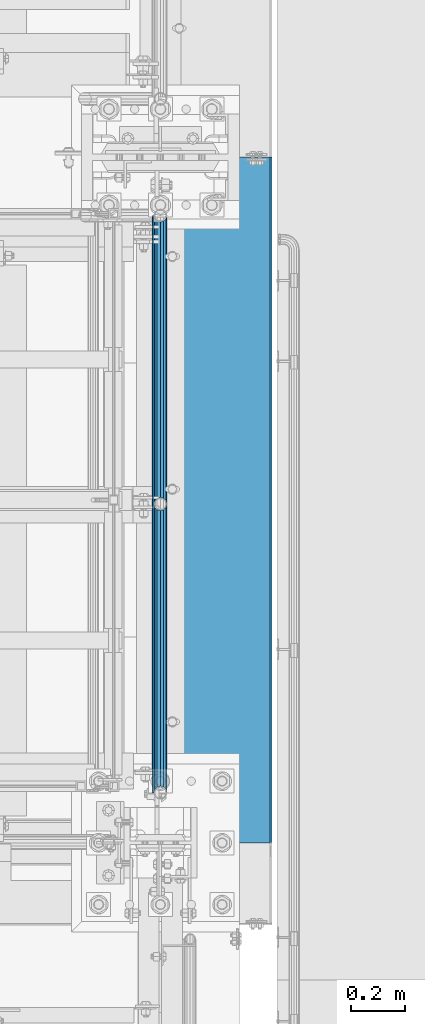
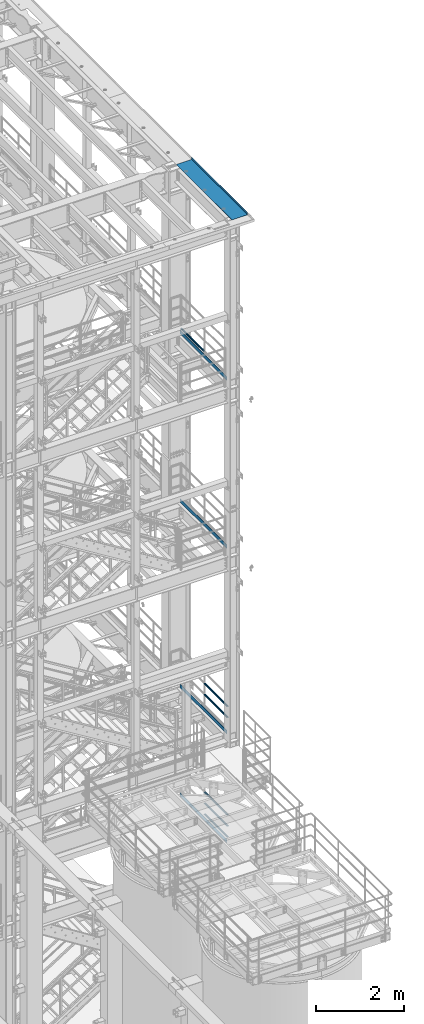
# One storey, part 1000 of 1876: 11 beams, 5 elements without a shape of their own.
"""IFC2X3 building model written with IfcOpenShell, lengths in millimetres."""

import ifcopenshell
import ifcopenshell.guid

model = None  # the IFC model being written
_history = None  # IfcOwnerHistory: only IFC2X3 demands one
_inside = {}  # id of a spatial element -> (the spatial element, [elements in it])
_under = {}  # id of a project, library or spatial element -> (it, [spatial elements below it])
_declared = {}  # id of a project -> (the project, [libraries it declares])
_typed = {}  # id of a type object -> (the type object, [elements of that type])
_made_of = {}  # id of a material, layer set ... -> (it, [elements and type objects made of it])


def new_model(schema):
    """Start an empty IFC model of exactly this schema.

    Asked for "IFC4X3", IfcOpenShell would pick the latest addendum, in which some entities
    have other attributes; the version numbers below select the first issue.
    IFC2X3 requires an IfcOwnerHistory on every rooted entity: one is made here for all.
    """
    global model, _history
    if schema == "IFC4X3":
        model = ifcopenshell.file(schema_version=(4, 3, 0, 0))
    else:
        model = ifcopenshell.file(schema=schema)
    _inside.clear()
    _under.clear()
    _declared.clear()
    _typed.clear()
    _made_of.clear()
    _history = None
    if model.schema == "IFC2X3":
        org = make("IfcOrganization", Name="unknown")
        user = make(
            "IfcPersonAndOrganization",
            ThePerson=make("IfcPerson", FamilyName="unknown"),
            TheOrganization=org,
        )
        app = make(
            "IfcApplication",
            ApplicationDeveloper=org,
            Version="unknown",
            ApplicationFullName="unknown",
            ApplicationIdentifier="unknown",
        )
        _history = make(
            "IfcOwnerHistory",
            OwningUser=user,
            OwningApplication=app,
            ChangeAction="ADDED",
            CreationDate=0,
        )
    return model


def make(cls, **values):
    """One entity of the class cls with the attributes given. An attribute that is None is left unset."""
    return model.create_entity(
        cls, **{name: value for name, value in values.items() if value is not None}
    )


def rooted(cls, **values):
    """An entity with a GlobalId (a new one), such as an element, a storey or a relation."""
    return make(cls, GlobalId=ifcopenshell.guid.new(), OwnerHistory=_history, **values)


def si_unit(unit_type, name, prefix=None):
    """IfcSIUnit, for example si_unit("LENGTHUNIT", "METRE", prefix="MILLI")."""
    return make("IfcSIUnit", UnitType=unit_type, Prefix=prefix, Name=name)


def assignment(units):
    """IfcUnitAssignment: the units of a project."""
    return None if units is None else make("IfcUnitAssignment", Units=units)


def point(xyz):
    """IfcCartesianPoint."""
    return None if xyz is None else make("IfcCartesianPoint", Coordinates=xyz)


def direction(xyz):
    """IfcDirection."""
    return None if xyz is None else make("IfcDirection", DirectionRatios=xyz)


def frame(location, z_axis=None, x_axis=None):
    """IfcAxis2Placement3D, a coordinate frame: its origin and axes. An axis left out is left unset."""
    return make(
        "IfcAxis2Placement3D",
        Location=point(location),
        Axis=direction(z_axis),
        RefDirection=direction(x_axis),
    )


def origin_with_axes():
    """The frame at (0, 0, 0) with the z axis (0, 0, 1) and the x axis (1, 0, 0) written out."""
    return frame((0.0, 0.0, 0.0), z_axis=(0.0, 0.0, 1.0), x_axis=(1.0, 0.0, 0.0))


def place(relative_to, where):
    """IfcLocalPlacement: puts the frame where relative to a parent placement (None: the world)."""
    return make(
        "IfcLocalPlacement", PlacementRelTo=relative_to, RelativePlacement=where
    )


def context(
    kind, dimensions, precision=None, world=None, true_north=None, identifier=None
):
    """IfcGeometricRepresentationContext, for example the 3D "Model" context."""
    return make(
        "IfcGeometricRepresentationContext",
        ContextIdentifier=identifier,
        ContextType=kind,
        CoordinateSpaceDimension=dimensions,
        Precision=precision,
        WorldCoordinateSystem=world,
        TrueNorth=true_north,
    )


def subcontext(parent, identifier, kind, view, scale=None):
    """IfcGeometricRepresentationSubContext, for example "Body" below "Model"."""
    return make(
        "IfcGeometricRepresentationSubContext",
        ContextIdentifier=identifier,
        ContextType=kind,
        ParentContext=parent,
        TargetScale=scale,
        TargetView=view,
    )


def project(units=None, contexts=None):
    """IfcProject with its units and contexts."""
    return rooted(
        "IfcProject",
        Name="project",
        RepresentationContexts=contexts,
        UnitsInContext=assignment(units),
    )


def spatial(cls, under=None, at=None, **own):
    """A site, building, storey or space (cls), placed at a placement, below another one or the project."""
    s = rooted(cls, ObjectPlacement=at, **own)
    if under is not None:
        _under.setdefault(under.id(), (under, []))[1].append(s)
    return s


def faces_of(points, faces, orient=None, outer=None):
    """IfcFace entities. A face is a list of loops; a loop is a list of indices into points, from 0.

    orient and outer hold one flag for each loop. By default every Orientation is true, the
    first loop of a face is its IfcFaceOuterBound and the others are IfcFaceBound.
    """
    made = []
    for i, loops in enumerate(faces):
        bounds = []
        for j, loop in enumerate(loops):
            is_outer = j == 0 if outer is None else outer[i][j]
            bounds.append(
                make(
                    "IfcFaceOuterBound" if is_outer else "IfcFaceBound",
                    Bound=make("IfcPolyLoop", Polygon=[points[k] for k in loop]),
                    Orientation=True if orient is None else orient[i][j],
                )
            )
        made.append(make("IfcFace", Bounds=bounds))
    return made


def faceted_brep(points, faces, orient=None, outer=None, voids=None):
    """IfcFacetedBrep: a solid bounded by flat faces; with voids (closed shells), ...WithVoids."""
    shared = [point(p) for p in points]
    hull = make("IfcClosedShell", CfsFaces=faces_of(shared, faces, orient, outer))
    if voids is None:
        return make("IfcFacetedBrep", Outer=hull)
    return make(
        "IfcFacetedBrepWithVoids",
        Outer=hull,
        Voids=[
            make(cls, CfsFaces=faces_of(shared, fs, o, b)) for cls, fs, o, b in voids
        ],
    )


def shape(context_of_items, identifier, shape_type, items):
    """IfcShapeRepresentation: the items that make up one representation, for example the "Body"."""
    return make(
        "IfcShapeRepresentation",
        ContextOfItems=context_of_items,
        RepresentationIdentifier=identifier,
        RepresentationType=shape_type,
        Items=items,
    )


def material(Name=None, Category=None):
    """IfcMaterial."""
    return make("IfcMaterial", Name=Name, Category=Category)


def made_of(thing, what):
    """Note that an element or type object is made of a material, layer set ...; save() writes the relation."""
    if what is not None:
        _made_of.setdefault(what.id(), (what, []))[1].append(thing)
    return thing


def type_object(cls, material=None, **own):
    """A type object (cls), such as IfcWallType, which elements share."""
    return made_of(rooted(cls, **own), material)


def element(
    cls,
    number,
    at=None,
    inside=None,
    cuts=None,
    type_object=None,
    material=None,
    context=None,
    identifier="Body",
    shape_type=None,
    held_by="IfcProductDefinitionShape",
    body=None,
    shapes=None,
    **own,
):
    """One element of the class cls, such as IfcWall. Its Tag is "e" and its number.

    at: its placement. inside: the storey or other place that contains it. cuts: it is an
    opening in that element (IfcRelVoidsElement). A single representation is given by context,
    identifier, shape_type and body (its items); several are given by shapes. held_by: the class
    of the entity that holds the representations. save() writes the other relations.
    """
    e = rooted(cls, Tag="e%d" % number, ObjectPlacement=at, **own)
    if body is not None:
        shapes = [shape(context, identifier, shape_type, body)]
    if shapes is not None:
        e.Representation = make(held_by, Representations=shapes)
    if inside is not None:
        _inside.setdefault(inside.id(), (inside, []))[1].append(e)
    if cuts is not None:
        rooted(
            "IfcRelVoidsElement", RelatingBuildingElement=cuts, RelatedOpeningElement=e
        )
    if type_object is not None:
        _typed.setdefault(type_object.id(), (type_object, []))[1].append(e)
    return made_of(e, material)


def aggregate(whole, parts):
    """IfcRelAggregates: a whole, such as a stair, and the parts it consists of."""
    return rooted("IfcRelAggregates", RelatingObject=whole, RelatedObjects=parts)


def save(model, path):
    """Write the relations noted so far, then the file.

    IfcRelAggregates (storeys below a building ...), IfcRelContainedInSpatialStructure (elements
    in a storey), IfcRelDefinesByType, IfcRelAssociatesMaterial and IfcRelDeclares: one each for
    every whole, place, type object, material and project.
    """
    for whole, parts in _under.values():
        aggregate(whole, parts)
    for where, things in _inside.values():
        rooted(
            "IfcRelContainedInSpatialStructure",
            RelatedElements=things,
            RelatingStructure=where,
        )
    for kind, things in _typed.values():
        rooted("IfcRelDefinesByType", RelatedObjects=things, RelatingType=kind)
    for what, things in _made_of.values():
        rooted("IfcRelAssociatesMaterial", RelatedObjects=things, RelatingMaterial=what)
    for by, libraries in _declared.values():
        rooted("IfcRelDeclares", RelatingContext=by, RelatedDefinitions=libraries)
    model.write(path)


model = new_model("IFC2X3")

# Units and contexts
model_context = context("Model", 3, precision=1e-05, world=origin_with_axes())
body_context = subcontext(model_context, "Body", "Model", "MODEL_VIEW")
ifc_project = project(units=[si_unit("LENGTHUNIT", "METRE", prefix="MILLI"), si_unit("AREAUNIT", "SQUARE_METRE"), si_unit("VOLUMEUNIT", "CUBIC_METRE"), si_unit("MASSUNIT", "GRAM", prefix="KILO"), si_unit("TIMEUNIT", "SECOND"), si_unit("PLANEANGLEUNIT", "RADIAN"), si_unit("SOLIDANGLEUNIT", "STERADIAN"), si_unit("THERMODYNAMICTEMPERATUREUNIT", "DEGREE_CELSIUS"), si_unit("LUMINOUSINTENSITYUNIT", "LUMEN")], contexts=[model_context])

# Site, building, storey
site_placement = place(None, origin_with_axes())
site = spatial("IfcSite", under=ifc_project, at=site_placement, CompositionType="ELEMENT")
building_placement = place(site_placement, origin_with_axes())
building = spatial("IfcBuilding", under=site, at=building_placement, Name="Undefined", CompositionType="ELEMENT")
storey_placement = place(building_placement, origin_with_axes())
storey = spatial("IfcBuildingStorey", under=building, at=storey_placement, Name="Undefined", CompositionType="ELEMENT", Elevation=0.0)

# Assembly, beam
assembly_1_placement = place(storey_placement, origin_with_axes())
assembly_1 = element("IfcElementAssembly", 1, at=assembly_1_placement, inside=storey, Name="RAIL", AssemblyPlace="NOTDEFINED", PredefinedType="RIGID_FRAME")
ifc_material_1 = material()
beam_type_1 = type_object("IfcBeamType", Name="PIPE1-1/2SCH40", PredefinedType="NOTDEFINED")
beam_1_placement = place(assembly_1_placement, frame((7619.99999999997, -4788.2175, 18145.125), z_axis=(0.0, 0.0, 1.0), x_axis=(0.0, -1.0, 0.0)))
beam_1 = element("IfcBeam", 2, at=beam_1_placement, type_object=beam_type_1, material=ifc_material_1, Name="RAIL", ObjectType="PIPE1-1/2SCH40", context=body_context, shape_type="Brep", body=[
    faceted_brep([(1047.96655700668, -12.0649999999996, 20.8971929933177), (1047.96655700668, -12.0649999999787, 15.8661214312015), (1047.47312856882, -10.2235000000001, 17.7076214311819), (1044.73375, 9.09494701772928e-13, 20.4470000000001), (1044.73375, 9.09494701772928e-13, 24.130000000001), (1047.47312856881, 10.2235000000001, 17.7076214311819), (1047.96655700668, 12.0650000000205, 15.8661214311578), (1047.96655700668, 12.0649999999996, 20.8971929933177), (1068.86375, 24.1300000000001, 0.0), (1056.79875, 20.8971929933186, 12.0649999999987), (1056.79875, 20.8971929933186, -12.0649999999987), (1053.60917843784, 17.7076214311801, 10.2235000000001), (1056.34855700666, 20.4470000000001, 0.0), (1053.60917843784, 17.7076214311801, -10.2235000000001), (1047.96655700668, 12.0650000000205, -15.8661214311578), (1047.96655700668, 12.0649999999996, -20.8971929933177), (1047.47312856881, 10.2235000000001, -17.7076214311819), (1044.73375, 0.0, -20.4470000000001), (1044.73375, 0.0, -24.130000000001), (1047.96655700668, -12.0649999999787, -15.8661214312015), (1047.96655700668, -12.0649999999996, -20.8971929933177), (1047.47312856882, -10.2235000000001, -17.7076214311819), (1068.86375, -24.1299999999792, 0.0), (1056.79875, -20.8971929933186, -12.0649999999987), (1056.79875, -20.8971929933186, 12.0649999999987), (1053.60917843788, -17.7076214311801, -10.2235000000001), (1056.3485570067, -20.4470000000001, 0.0), (1053.60917843788, -17.7076214311801, 10.2235000000001), (12.0650000000064, -20.8971929933177, -12.0649999999987), (20.8971929933249, -12.0650000000005, -20.8971929933177), (0.0, 24.1299999999992, 0.0), (12.0650000000064, 20.8971929933177, -12.0649999999987), (12.0650000000064, 20.8971929933177, 12.0649999999987), (20.8971929933249, 12.0650000000005, 20.8971929933177), (24.1300000000064, 0.0, 24.130000000001), (20.8971929933249, 12.0650000000005, -20.8971929933177), (24.1300000000063, 0.0, -24.130000000001), (24.1300000000063, 0.0, -20.4470000000001), (20.8971929933249, -12.0650000000005, -15.8661214311796), (21.3906214311868, -10.2235000000001, -17.7076214311819), (21.3906214311868, 10.2235000000001, -17.7076214311819), (20.8971929933249, 12.0650000000005, -15.8661214311796), (15.2545715621445, 17.7076214311801, -10.2235000000001), (12.5151929933249, 20.4470000000001, 0.0), (15.2545715621445, 17.7076214311801, 10.2235000000001), (20.8971929933249, 12.0650000000005, 15.8661214311796), (21.3906214311868, 10.2235000000001, 17.7076214311819), (24.1300000000064, 0.0, 20.4470000000001), (21.3906214311868, -10.2235000000001, 17.7076214311819), (20.8971929933249, -12.0650000000005, 15.8661214311796), (20.8971929933249, -12.0650000000005, 20.8971929933177), (12.0650000000064, -20.8971929933177, 12.0649999999987), (0.0, -24.1299999999992, 0.0), (15.2545715621445, -17.7076214311801, 10.2235000000001), (12.5151929933249, -20.4470000000001, 0.0), (15.2545715621445, -17.7076214311801, -10.2235000000001)], [[[0, 1, 2, 3, 4]], [[4, 3, 5, 6, 7]], [[8, 9, 10]], [[7, 6, 11, 12, 13, 14, 15, 10, 9]], [[16, 17, 18, 15, 14]], [[19, 20, 18, 17, 21]], [[22, 23, 24]], [[24, 23, 20, 19, 25, 26, 27, 1, 0]], [[28, 29, 20, 23]], [[30, 31, 32]], [[33, 34, 4, 7]], [[32, 33, 7, 9]], [[30, 32, 9, 8]], [[31, 30, 8, 10]], [[35, 31, 10, 15]], [[36, 35, 15, 18]], [[29, 36, 18, 20]], [[37, 36, 29, 38, 39]], [[40, 41, 35, 36, 37]], [[32, 31, 35, 41, 42, 43, 44, 45, 33]], [[33, 45, 46, 47, 34]], [[34, 47, 48, 49, 50]], [[34, 50, 0, 4]], [[50, 51, 24, 0]], [[51, 52, 22, 24]], [[52, 28, 23, 22]], [[51, 28, 52]], [[50, 49, 53, 54, 55, 38, 29, 28, 51]], [[55, 54, 26, 25]], [[21, 39, 38, 55, 25, 19]], [[37, 39, 21, 17]], [[40, 37, 17, 16]], [[42, 41, 40, 16, 14, 13]], [[43, 42, 13, 12]], [[44, 43, 12, 11]], [[5, 46, 45, 44, 11, 6]], [[47, 46, 5, 3]], [[48, 47, 3, 2]], [[53, 49, 48, 2, 1, 27]], [[54, 53, 27, 26]]]),
])

# Assembly, beams
assembly_2_placement = place(storey_placement, origin_with_axes())
assembly_2 = element("IfcElementAssembly", 3, at=assembly_2_placement, inside=storey, Name="RAIL", AssemblyPlace="NOTDEFINED", PredefinedType="RIGID_FRAME")
beam_2_placement = place(assembly_2_placement, frame((7620.00000000003, -6925.94499999999, 8620.125), z_axis=(0.0, 0.0, -1.0), x_axis=(0.0, 1.0, 0.0)))
beam_2 = element("IfcBeam", 4, at=beam_2_placement, type_object=beam_type_1, material=ifc_material_1, Name="RAIL", ObjectType="PIPE1-1/2SCH40", context=body_context, shape_type="Brep", body=[
    faceted_brep([(0.0, 24.1299999999992, 0.0), (12.0650000000064, 20.8971929933177, -12.0649999999987), (12.0650000000064, 20.8971929933177, 12.0649999999987), (12.0650000000064, -20.8971929933177, 12.0649999999987), (12.0650000000064, -20.8971929933177, -12.0649999999987), (0.0, -24.1299999999992, 0.0), (20.8971929933249, -12.0650000000005, 20.8971929933177), (20.8971929933249, -12.0650000000005, 15.8661214311796), (15.2545715621445, -17.7076214311801, 10.2235000000001), (12.5151929933249, -20.4470000000001, 0.0), (15.2545715621445, -17.7076214311801, -10.2235000000001), (20.8971929933249, -12.0650000000005, -15.8661214311796), (20.8971929933249, -12.0650000000005, -20.8971929933177), (24.1300000000063, 0.0, -20.4470000000001), (24.1300000000063, 0.0, -24.130000000001), (21.3906214311868, -10.2235000000001, -17.7076214311819), (21.3906214311868, 10.2235000000001, -17.7076214311819), (20.8971929933249, 12.0650000000005, -15.8661214311796), (20.8971929933249, 12.0650000000005, -20.8971929933177), (15.2545715621445, 17.7076214311801, -10.2235000000001), (12.5151929933249, 20.4470000000001, 0.0), (15.2545715621445, 17.7076214311801, 10.2235000000001), (20.8971929933249, 12.0650000000005, 15.8661214311796), (20.8971929933249, 12.0650000000005, 20.8971929933177), (21.3906214311868, 10.2235000000001, 17.7076214311819), (24.1300000000064, 0.0, 20.4470000000001), (24.1300000000064, 0.0, 24.130000000001), (21.3906214311868, -10.2235000000001, 17.7076214311819), (1068.86375, 24.1300000000001, 0.0), (1056.79875, 20.8971929933186, -12.0649999999987), (1047.96655700668, 12.0649999999996, -20.8971929933177), (1068.86375, -24.1299999999792, 0.0), (1056.79875, -20.8971929933186, -12.0649999999987), (1056.79875, -20.8971929933186, 12.0649999999987), (1047.96655700668, -12.0649999999996, 20.8971929933177), (1047.96655700668, -12.0649999999996, -20.8971929933177), (1044.73375, 0.0, -24.130000000001), (1047.47312856881, 10.2235000000001, -17.7076214311819), (1044.73375, 0.0, -20.4470000000001), (1047.96655700668, 12.0650000000205, -15.8661214311578), (1047.96655700668, -12.0649999999787, -15.8661214312015), (1047.47312856882, -10.2235000000001, -17.7076214311819), (1053.60917843788, -17.7076214311801, -10.2235000000001), (1056.3485570067, -20.4470000000001, 0.0), (1053.60917843788, -17.7076214311801, 10.2235000000001), (1047.96655700668, -12.0649999999787, 15.8661214312015), (1047.47312856882, -10.2235000000001, 17.7076214311819), (1044.73375, 9.09494701772928e-13, 20.4470000000001), (1044.73375, 9.09494701772928e-13, 24.130000000001), (1047.96655700668, 12.0649999999996, 20.8971929933177), (1056.79875, 20.8971929933186, 12.0649999999987), (1047.96655700668, 12.0650000000205, 15.8661214311578), (1053.60917843784, 17.7076214311801, 10.2235000000001), (1056.34855700666, 20.4470000000001, 0.0), (1053.60917843784, 17.7076214311801, -10.2235000000001), (1047.47312856881, 10.2235000000001, 17.7076214311819)], [[[0, 1, 2]], [[3, 4, 5]], [[6, 7, 8, 9, 10, 11, 12, 4, 3]], [[13, 14, 12, 11, 15]], [[16, 17, 18, 14, 13]], [[2, 1, 18, 17, 19, 20, 21, 22, 23]], [[23, 22, 24, 25, 26]], [[26, 25, 27, 7, 6]], [[1, 0, 28, 29]], [[18, 1, 29, 30]], [[31, 32, 33]], [[6, 3, 33, 34]], [[3, 5, 31, 33]], [[5, 4, 32, 31]], [[4, 12, 35, 32]], [[12, 14, 36, 35]], [[14, 18, 30, 36]], [[37, 38, 36, 30, 39]], [[40, 35, 36, 38, 41]], [[33, 32, 35, 40, 42, 43, 44, 45, 34]], [[34, 45, 46, 47, 48]], [[26, 6, 34, 48]], [[2, 23, 49, 50]], [[23, 26, 48, 49]], [[0, 2, 50, 28]], [[28, 50, 29]], [[49, 51, 52, 53, 54, 39, 30, 29, 50]], [[48, 47, 55, 51, 49]], [[25, 24, 55, 47]], [[55, 24, 22, 21, 52, 51]], [[21, 20, 53, 52]], [[20, 19, 54, 53]], [[19, 17, 16, 37, 39, 54]], [[16, 13, 38, 37]], [[13, 15, 41, 38]], [[41, 15, 11, 10, 42, 40]], [[10, 9, 43, 42]], [[9, 8, 44, 43]], [[8, 7, 27, 46, 45, 44]], [[27, 25, 47, 46]]]),
])
beam_3_placement = place(assembly_2_placement, frame((7620.00000000003, -6925.94499999999, 8924.925), z_axis=(0.0, 0.0, -1.0), x_axis=(0.0, 1.0, 0.0)))
beam_3 = element("IfcBeam", 5, at=beam_3_placement, type_object=beam_type_1, material=ifc_material_1, Name="RAIL", ObjectType="PIPE1-1/2SCH40", context=body_context, shape_type="Brep", body=[
    faceted_brep([(0.0, 24.1299999999992, 0.0), (12.0650000000064, 20.8971929933177, -12.0649999999987), (12.0650000000064, 20.8971929933177, 12.0649999999987), (12.0650000000064, -20.8971929933177, 12.0649999999987), (12.0650000000064, -20.8971929933177, -12.0649999999987), (0.0, -24.1299999999992, 0.0), (20.8971929933249, -12.0650000000005, 20.8971929933177), (20.8971929933249, -12.0650000000005, 15.8661214311796), (15.2545715621445, -17.7076214311801, 10.2235000000001), (12.5151929933249, -20.4470000000001, 0.0), (15.2545715621445, -17.7076214311801, -10.2235000000001), (20.8971929933249, -12.0650000000005, -15.8661214311796), (20.8971929933249, -12.0650000000005, -20.8971929933177), (24.1300000000063, 0.0, -20.4470000000001), (24.1300000000063, 0.0, -24.130000000001), (21.3906214311868, -10.2235000000001, -17.7076214311819), (21.3906214311868, 10.2235000000001, -17.7076214311819), (20.8971929933249, 12.0650000000005, -15.8661214311796), (20.8971929933249, 12.0650000000005, -20.8971929933177), (15.2545715621445, 17.7076214311801, -10.2235000000001), (12.5151929933249, 20.4470000000001, 0.0), (15.2545715621445, 17.7076214311801, 10.2235000000001), (20.8971929933249, 12.0650000000005, 15.8661214311796), (20.8971929933249, 12.0650000000005, 20.8971929933177), (21.3906214311868, 10.2235000000001, 17.7076214311819), (24.1300000000064, 0.0, 20.4470000000001), (24.1300000000064, 0.0, 24.130000000001), (21.3906214311868, -10.2235000000001, 17.7076214311819), (1068.86375, 24.1300000000001, 0.0), (1056.79875, 20.8971929933186, -12.0649999999987), (1047.96655700668, 12.0649999999996, -20.8971929933177), (1068.86375, -24.1299999999792, 0.0), (1056.79875, -20.8971929933186, -12.0649999999987), (1056.79875, -20.8971929933186, 12.0649999999987), (1047.96655700668, -12.0649999999996, 20.8971929933177), (1047.96655700668, -12.0649999999996, -20.8971929933177), (1044.73375, 0.0, -24.130000000001), (1047.47312856881, 10.2235000000001, -17.7076214311819), (1044.73375, 0.0, -20.4470000000001), (1047.96655700668, 12.0650000000205, -15.8661214311578), (1047.96655700668, -12.0649999999787, -15.8661214312015), (1047.47312856882, -10.2235000000001, -17.7076214311819), (1053.60917843788, -17.7076214311801, -10.2235000000001), (1056.3485570067, -20.4470000000001, 0.0), (1053.60917843788, -17.7076214311801, 10.2235000000001), (1047.96655700668, -12.0649999999787, 15.8661214312015), (1047.47312856882, -10.2235000000001, 17.7076214311819), (1044.73375, 9.09494701772928e-13, 20.4470000000001), (1044.73375, 9.09494701772928e-13, 24.130000000001), (1047.96655700668, 12.0649999999996, 20.8971929933177), (1056.79875, 20.8971929933186, 12.0649999999987), (1047.96655700668, 12.0650000000205, 15.8661214311578), (1053.60917843784, 17.7076214311801, 10.2235000000001), (1056.34855700666, 20.4470000000001, 0.0), (1053.60917843784, 17.7076214311801, -10.2235000000001), (1047.47312856881, 10.2235000000001, 17.7076214311819)], [[[0, 1, 2]], [[3, 4, 5]], [[6, 7, 8, 9, 10, 11, 12, 4, 3]], [[13, 14, 12, 11, 15]], [[16, 17, 18, 14, 13]], [[2, 1, 18, 17, 19, 20, 21, 22, 23]], [[23, 22, 24, 25, 26]], [[26, 25, 27, 7, 6]], [[1, 0, 28, 29]], [[18, 1, 29, 30]], [[31, 32, 33]], [[6, 3, 33, 34]], [[3, 5, 31, 33]], [[5, 4, 32, 31]], [[4, 12, 35, 32]], [[12, 14, 36, 35]], [[14, 18, 30, 36]], [[37, 38, 36, 30, 39]], [[40, 35, 36, 38, 41]], [[33, 32, 35, 40, 42, 43, 44, 45, 34]], [[34, 45, 46, 47, 48]], [[26, 6, 34, 48]], [[2, 23, 49, 50]], [[23, 26, 48, 49]], [[0, 2, 50, 28]], [[28, 50, 29]], [[49, 51, 52, 53, 54, 39, 30, 29, 50]], [[48, 47, 55, 51, 49]], [[25, 24, 55, 47]], [[55, 24, 22, 21, 52, 51]], [[21, 20, 53, 52]], [[20, 19, 54, 53]], [[19, 17, 16, 37, 39, 54]], [[16, 13, 38, 37]], [[13, 15, 41, 38]], [[41, 15, 11, 10, 42, 40]], [[10, 9, 43, 42]], [[9, 8, 44, 43]], [[8, 7, 27, 46, 45, 44]], [[27, 25, 47, 46]]]),
])

assembly_3_placement = place(storey_placement, origin_with_axes())
assembly_3 = element("IfcElementAssembly", 6, at=assembly_3_placement, inside=storey, Name="RAIL", AssemblyPlace="NOTDEFINED", PredefinedType="RIGID_FRAME")
beam_4_placement = place(assembly_3_placement, frame((7620.00000000067, -5857.08125000002, 5292.72500110549), z_axis=(0.0, 0.0, 1.0), x_axis=(0.0, -1.0, 0.0)))
beam_4 = element("IfcBeam", 7, at=beam_4_placement, type_object=beam_type_1, material=ifc_material_1, Name="RAIL", ObjectType="PIPE1-1/2SCH40", context=body_context, shape_type="Brep", body=[
    faceted_brep([(1047.96655700668, -12.0649999999996, 20.8971929933177), (1047.96655700668, -12.0649999999787, 15.8661214312015), (1047.47312856882, -10.2235000000001, 17.7076214311819), (1044.73375, 9.09494701772928e-13, 20.4470000000001), (1044.73375, 9.09494701772928e-13, 24.130000000001), (1047.47312856881, 10.2235000000001, 17.7076214311819), (1047.96655700668, 12.0650000000205, 15.8661214311578), (1047.96655700668, 12.0649999999996, 20.8971929933177), (1068.86375, 24.1300000000001, 0.0), (1056.79875, 20.8971929933186, 12.0649999999987), (1056.79875, 20.8971929933186, -12.0649999999987), (1053.60917843784, 17.7076214311801, 10.2235000000001), (1056.34855700666, 20.4470000000001, 0.0), (1053.60917843784, 17.7076214311801, -10.2235000000001), (1047.96655700668, 12.0650000000205, -15.8661214311578), (1047.96655700668, 12.0649999999996, -20.8971929933177), (1047.47312856881, 10.2235000000001, -17.7076214311819), (1044.73375, 0.0, -20.4470000000001), (1044.73375, 0.0, -24.130000000001), (1047.96655700668, -12.0649999999787, -15.8661214312015), (1047.96655700668, -12.0649999999996, -20.8971929933177), (1047.47312856882, -10.2235000000001, -17.7076214311819), (1068.86375, -24.1299999999792, 0.0), (1056.79875, -20.8971929933186, -12.0649999999987), (1056.79875, -20.8971929933186, 12.0649999999987), (1053.60917843788, -17.7076214311801, -10.2235000000001), (1056.3485570067, -20.4470000000001, 0.0), (1053.60917843788, -17.7076214311801, 10.2235000000001), (12.0650000000064, -20.8971929933177, -12.0649999999987), (20.8971929933249, -12.0650000000005, -20.8971929933177), (0.0, 24.1299999999992, 0.0), (12.0650000000064, 20.8971929933177, -12.0649999999987), (12.0650000000064, 20.8971929933177, 12.0649999999987), (20.8971929933249, 12.0650000000005, 20.8971929933177), (24.1300000000064, 0.0, 24.130000000001), (20.8971929933249, 12.0650000000005, -20.8971929933177), (24.1300000000063, 0.0, -24.130000000001), (24.1300000000063, 0.0, -20.4470000000001), (20.8971929933249, -12.0650000000005, -15.8661214311796), (21.3906214311868, -10.2235000000001, -17.7076214311819), (21.3906214311868, 10.2235000000001, -17.7076214311819), (20.8971929933249, 12.0650000000005, -15.8661214311796), (15.2545715621445, 17.7076214311801, -10.2235000000001), (12.5151929933249, 20.4470000000001, 0.0), (15.2545715621445, 17.7076214311801, 10.2235000000001), (20.8971929933249, 12.0650000000005, 15.8661214311796), (21.3906214311868, 10.2235000000001, 17.7076214311819), (24.1300000000064, 0.0, 20.4470000000001), (21.3906214311868, -10.2235000000001, 17.7076214311819), (20.8971929933249, -12.0650000000005, 15.8661214311796), (20.8971929933249, -12.0650000000005, 20.8971929933177), (12.0650000000064, -20.8971929933177, 12.0649999999987), (0.0, -24.1299999999992, 0.0), (15.2545715621445, -17.7076214311801, 10.2235000000001), (12.5151929933249, -20.4470000000001, 0.0), (15.2545715621445, -17.7076214311801, -10.2235000000001)], [[[0, 1, 2, 3, 4]], [[4, 3, 5, 6, 7]], [[8, 9, 10]], [[7, 6, 11, 12, 13, 14, 15, 10, 9]], [[16, 17, 18, 15, 14]], [[19, 20, 18, 17, 21]], [[22, 23, 24]], [[24, 23, 20, 19, 25, 26, 27, 1, 0]], [[28, 29, 20, 23]], [[30, 31, 32]], [[33, 34, 4, 7]], [[32, 33, 7, 9]], [[30, 32, 9, 8]], [[31, 30, 8, 10]], [[35, 31, 10, 15]], [[36, 35, 15, 18]], [[29, 36, 18, 20]], [[37, 36, 29, 38, 39]], [[40, 41, 35, 36, 37]], [[32, 31, 35, 41, 42, 43, 44, 45, 33]], [[33, 45, 46, 47, 34]], [[34, 47, 48, 49, 50]], [[34, 50, 0, 4]], [[50, 51, 24, 0]], [[51, 52, 22, 24]], [[52, 28, 23, 22]], [[51, 28, 52]], [[50, 49, 53, 54, 55, 38, 29, 28, 51]], [[55, 54, 26, 25]], [[21, 39, 38, 55, 25, 19]], [[37, 39, 21, 17]], [[40, 37, 17, 16]], [[42, 41, 40, 16, 14, 13]], [[43, 42, 13, 12]], [[44, 43, 12, 11]], [[5, 46, 45, 44, 11, 6]], [[47, 46, 5, 3]], [[48, 47, 3, 2]], [[53, 49, 48, 2, 1, 27]], [[54, 53, 27, 26]]]),
])
beam_5_placement = place(assembly_3_placement, frame((7619.99999999996, -6925.94500000002, 5597.525), z_axis=(0.0, 0.0, -1.0), x_axis=(0.0, 1.0, 0.0)))
beam_5 = element("IfcBeam", 8, at=beam_5_placement, type_object=beam_type_1, material=ifc_material_1, Name="RAIL", ObjectType="PIPE1-1/2SCH40", context=body_context, shape_type="Brep", body=[
    faceted_brep([(0.0, 24.1299999999992, 0.0), (12.0650000000064, 20.8971929933177, -12.0649999999987), (12.0650000000064, 20.8971929933177, 12.0649999999987), (12.0650000000064, -20.8971929933177, 12.0649999999987), (12.0650000000064, -20.8971929933177, -12.0649999999987), (0.0, -24.1299999999992, 0.0), (20.8971929933249, -12.0650000000005, 20.8971929933177), (20.8971929933249, -12.0650000000005, 15.8661214311796), (15.2545715621445, -17.7076214311801, 10.2235000000001), (12.5151929933249, -20.4470000000001, 0.0), (15.2545715621445, -17.7076214311801, -10.2235000000001), (20.8971929933249, -12.0650000000005, -15.8661214311796), (20.8971929933249, -12.0650000000005, -20.8971929933177), (24.1300000000063, 0.0, -20.4470000000001), (24.1300000000063, 0.0, -24.130000000001), (21.3906214311868, -10.2235000000001, -17.7076214311819), (21.3906214311868, 10.2235000000001, -17.7076214311819), (20.8971929933249, 12.0650000000005, -15.8661214311796), (20.8971929933249, 12.0650000000005, -20.8971929933177), (15.2545715621445, 17.7076214311801, -10.2235000000001), (12.5151929933249, 20.4470000000001, 0.0), (15.2545715621445, 17.7076214311801, 10.2235000000001), (20.8971929933249, 12.0650000000005, 15.8661214311796), (20.8971929933249, 12.0650000000005, 20.8971929933177), (21.3906214311868, 10.2235000000001, 17.7076214311819), (24.1300000000064, 0.0, 20.4470000000001), (24.1300000000064, 0.0, 24.130000000001), (21.3906214311868, -10.2235000000001, 17.7076214311819), (1068.86375, 24.1300000000001, 0.0), (1056.79875, 20.8971929933186, -12.0649999999987), (1047.96655700668, 12.0649999999996, -20.8971929933177), (1068.86375, -24.1299999999792, 0.0), (1056.79875, -20.8971929933186, -12.0649999999987), (1056.79875, -20.8971929933186, 12.0649999999987), (1047.96655700668, -12.0649999999996, 20.8971929933177), (1047.96655700668, -12.0649999999996, -20.8971929933177), (1044.73375, 0.0, -24.130000000001), (1047.47312856881, 10.2235000000001, -17.7076214311819), (1044.73375, 0.0, -20.4470000000001), (1047.96655700668, 12.0650000000205, -15.8661214311578), (1047.96655700668, -12.0649999999787, -15.8661214312015), (1047.47312856882, -10.2235000000001, -17.7076214311819), (1053.60917843788, -17.7076214311801, -10.2235000000001), (1056.3485570067, -20.4470000000001, 0.0), (1053.60917843788, -17.7076214311801, 10.2235000000001), (1047.96655700668, -12.0649999999787, 15.8661214312015), (1047.47312856882, -10.2235000000001, 17.7076214311819), (1044.73375, 9.09494701772928e-13, 20.4470000000001), (1044.73375, 9.09494701772928e-13, 24.130000000001), (1047.96655700668, 12.0649999999996, 20.8971929933177), (1056.79875, 20.8971929933186, 12.0649999999987), (1047.96655700668, 12.0650000000205, 15.8661214311578), (1053.60917843784, 17.7076214311801, 10.2235000000001), (1056.34855700666, 20.4470000000001, 0.0), (1053.60917843784, 17.7076214311801, -10.2235000000001), (1047.47312856881, 10.2235000000001, 17.7076214311819)], [[[0, 1, 2]], [[3, 4, 5]], [[6, 7, 8, 9, 10, 11, 12, 4, 3]], [[13, 14, 12, 11, 15]], [[16, 17, 18, 14, 13]], [[2, 1, 18, 17, 19, 20, 21, 22, 23]], [[23, 22, 24, 25, 26]], [[26, 25, 27, 7, 6]], [[1, 0, 28, 29]], [[18, 1, 29, 30]], [[31, 32, 33]], [[6, 3, 33, 34]], [[3, 5, 31, 33]], [[5, 4, 32, 31]], [[4, 12, 35, 32]], [[12, 14, 36, 35]], [[14, 18, 30, 36]], [[37, 38, 36, 30, 39]], [[40, 35, 36, 38, 41]], [[33, 32, 35, 40, 42, 43, 44, 45, 34]], [[34, 45, 46, 47, 48]], [[26, 6, 34, 48]], [[2, 23, 49, 50]], [[23, 26, 48, 49]], [[0, 2, 50, 28]], [[28, 50, 29]], [[49, 51, 52, 53, 54, 39, 30, 29, 50]], [[48, 47, 55, 51, 49]], [[25, 24, 55, 47]], [[55, 24, 22, 21, 52, 51]], [[21, 20, 53, 52]], [[20, 19, 54, 53]], [[19, 17, 16, 37, 39, 54]], [[16, 13, 38, 37]], [[13, 15, 41, 38]], [[41, 15, 11, 10, 42, 40]], [[10, 9, 43, 42]], [[9, 8, 44, 43]], [[8, 7, 27, 46, 45, 44]], [[27, 25, 47, 46]]]),
])
beam_6_placement = place(assembly_3_placement, frame((7620.00000000031, -6925.94500000002, 5902.32500000031), z_axis=(0.0, 0.0, -1.0), x_axis=(0.0, 1.0, 0.0)))
beam_6 = element("IfcBeam", 9, at=beam_6_placement, type_object=beam_type_1, material=ifc_material_1, Name="RAIL", ObjectType="PIPE1-1/2SCH40", context=body_context, shape_type="Brep", body=[
    faceted_brep([(0.0, 24.1299999999992, 0.0), (12.0650000000064, 20.8971929933177, -12.0649999999987), (12.0650000000064, 20.8971929933177, 12.0649999999987), (12.0650000000064, -20.8971929933177, 12.0649999999987), (12.0650000000064, -20.8971929933177, -12.0649999999987), (0.0, -24.1299999999992, 0.0), (20.8971929933249, -12.0650000000005, 20.8971929933177), (20.8971929933249, -12.0650000000005, 15.8661214311796), (15.2545715621445, -17.7076214311801, 10.2235000000001), (12.5151929933249, -20.4470000000001, 0.0), (15.2545715621445, -17.7076214311801, -10.2235000000001), (20.8971929933249, -12.0650000000005, -15.8661214311796), (20.8971929933249, -12.0650000000005, -20.8971929933177), (24.1300000000063, 0.0, -20.4470000000001), (24.1300000000063, 0.0, -24.130000000001), (21.3906214311868, -10.2235000000001, -17.7076214311819), (21.3906214311868, 10.2235000000001, -17.7076214311819), (20.8971929933249, 12.0650000000005, -15.8661214311796), (20.8971929933249, 12.0650000000005, -20.8971929933177), (15.2545715621445, 17.7076214311801, -10.2235000000001), (12.5151929933249, 20.4470000000001, 0.0), (15.2545715621445, 17.7076214311801, 10.2235000000001), (20.8971929933249, 12.0650000000005, 15.8661214311796), (20.8971929933249, 12.0650000000005, 20.8971929933177), (21.3906214311868, 10.2235000000001, 17.7076214311819), (24.1300000000064, 0.0, 20.4470000000001), (24.1300000000064, 0.0, 24.130000000001), (21.3906214311868, -10.2235000000001, 17.7076214311819), (1068.86375, 24.1300000000001, 0.0), (1056.79875, 20.8971929933186, -12.0649999999987), (1047.96655700668, 12.0649999999996, -20.8971929933177), (1068.86375, -24.1299999999792, 0.0), (1056.79875, -20.8971929933186, -12.0649999999987), (1056.79875, -20.8971929933186, 12.0649999999987), (1047.96655700668, -12.0649999999996, 20.8971929933177), (1047.96655700668, -12.0649999999996, -20.8971929933177), (1044.73375, 0.0, -24.130000000001), (1047.47312856881, 10.2235000000001, -17.7076214311819), (1044.73375, 0.0, -20.4470000000001), (1047.96655700668, 12.0650000000205, -15.8661214311578), (1047.96655700668, -12.0649999999787, -15.8661214312015), (1047.47312856882, -10.2235000000001, -17.7076214311819), (1053.60917843788, -17.7076214311801, -10.2235000000001), (1056.3485570067, -20.4470000000001, 0.0), (1053.60917843788, -17.7076214311801, 10.2235000000001), (1047.96655700668, -12.0649999999787, 15.8661214312015), (1047.47312856882, -10.2235000000001, 17.7076214311819), (1044.73375, 9.09494701772928e-13, 20.4470000000001), (1044.73375, 9.09494701772928e-13, 24.130000000001), (1047.96655700668, 12.0649999999996, 20.8971929933177), (1056.79875, 20.8971929933186, 12.0649999999987), (1047.96655700668, 12.0650000000205, 15.8661214311578), (1053.60917843784, 17.7076214311801, 10.2235000000001), (1056.34855700666, 20.4470000000001, 0.0), (1053.60917843784, 17.7076214311801, -10.2235000000001), (1047.47312856881, 10.2235000000001, 17.7076214311819)], [[[0, 1, 2]], [[3, 4, 5]], [[6, 7, 8, 9, 10, 11, 12, 4, 3]], [[13, 14, 12, 11, 15]], [[16, 17, 18, 14, 13]], [[2, 1, 18, 17, 19, 20, 21, 22, 23]], [[23, 22, 24, 25, 26]], [[26, 25, 27, 7, 6]], [[1, 0, 28, 29]], [[18, 1, 29, 30]], [[31, 32, 33]], [[6, 3, 33, 34]], [[3, 5, 31, 33]], [[5, 4, 32, 31]], [[4, 12, 35, 32]], [[12, 14, 36, 35]], [[14, 18, 30, 36]], [[37, 38, 36, 30, 39]], [[40, 35, 36, 38, 41]], [[33, 32, 35, 40, 42, 43, 44, 45, 34]], [[34, 45, 46, 47, 48]], [[26, 6, 34, 48]], [[2, 23, 49, 50]], [[23, 26, 48, 49]], [[0, 2, 50, 28]], [[28, 50, 29]], [[49, 51, 52, 53, 54, 39, 30, 29, 50]], [[48, 47, 55, 51, 49]], [[25, 24, 55, 47]], [[55, 24, 22, 21, 52, 51]], [[21, 20, 53, 52]], [[20, 19, 54, 53]], [[19, 17, 16, 37, 39, 54]], [[16, 13, 38, 37]], [[13, 15, 41, 38]], [[41, 15, 11, 10, 42, 40]], [[10, 9, 43, 42]], [[9, 8, 44, 43]], [[8, 7, 27, 46, 45, 44]], [[27, 25, 47, 46]]]),
])

# Beam
ifc_material_2 = material(Name="STEEL/A36")
beam_type_2 = type_object("IfcBeamType", PredefinedType="NOTDEFINED")
beam_7_placement = place(assembly_1_placement, frame((7592.69500000001, -6925.945, 18049.875), z_axis=(0.0, 0.0, 1.0), x_axis=(0.0, 1.0, 0.0)))
beam_7 = element("IfcBeam", 10, at=beam_7_placement, type_object=beam_type_2, material=ifc_material_2, Name="PLATE", context=body_context, shape_type="Brep", body=[
    faceted_brep([(0.0, 3.17500000000018, -50.8000000000002), (0.0, 3.17500000000018, 50.8000000000002), (2137.7275, 3.175, 50.7999999999993), (2137.7275, 3.175, -50.7999999999993), (0.0, -3.17500000000018, 50.8000000000002), (2137.7275, -3.175, 50.7999999999993), (0.0, -3.17500000000018, -50.8000000000002), (2137.7275, -3.175, -50.7999999999993)], [[[0, 1, 2, 3]], [[1, 4, 5, 2]], [[4, 6, 7, 5]], [[6, 0, 3, 7]], [[5, 7, 3, 2]], [[6, 4, 1, 0]]]),
])

aggregate(assembly_1, [beam_7, beam_1])

# Assembly, beam
assembly_4_placement = place(storey_placement, origin_with_axes())
assembly_4 = element("IfcElementAssembly", 11, at=assembly_4_placement, inside=storey, Name="RAIL", AssemblyPlace="NOTDEFINED", PredefinedType="RIGID_FRAME")
beam_8_placement = place(assembly_4_placement, frame((7592.69500000001, -6925.945, 13376.275), z_axis=(0.0, 0.0, 1.0), x_axis=(0.0, 1.0, 0.0)))
beam_8 = element("IfcBeam", 12, at=beam_8_placement, type_object=beam_type_2, material=ifc_material_2, Name="PLATE", context=body_context, shape_type="Brep", body=[
    faceted_brep([(0.0, 3.17500000000018, -50.8000000000002), (0.0, 3.17500000000018, 50.8000000000002), (2137.7275, 3.175, 50.7999999999993), (2137.7275, 3.175, -50.7999999999993), (0.0, -3.17500000000018, 50.8000000000002), (2137.7275, -3.175, 50.7999999999993), (0.0, -3.17500000000018, -50.8000000000002), (2137.7275, -3.175, -50.7999999999993)], [[[0, 1, 2, 3]], [[1, 4, 5, 2]], [[4, 6, 7, 5]], [[6, 0, 3, 7]], [[5, 7, 3, 2]], [[6, 4, 1, 0]]]),
])
aggregate(assembly_4, [beam_8])

# Beam
beam_9_placement = place(assembly_2_placement, frame((7592.69500000001, -6925.945, 8220.075), z_axis=(0.0, 0.0, 1.0), x_axis=(0.0, 1.0, 0.0)))
beam_9 = element("IfcBeam", 13, at=beam_9_placement, type_object=beam_type_2, material=ifc_material_2, Name="PLATE", context=body_context, shape_type="Brep", body=[
    faceted_brep([(0.0, 3.17500000000018, -50.8000000000002), (0.0, 3.17500000000018, 50.8000000000002), (2137.7275, 3.175, 50.7999999999993), (2137.7275, 3.175, -50.7999999999993), (0.0, -3.17500000000018, 50.8000000000002), (2137.7275, -3.175, 50.7999999999993), (0.0, -3.17500000000018, -50.8000000000002), (2137.7275, -3.175, -50.7999999999993)], [[[0, 1, 2, 3]], [[1, 4, 5, 2]], [[4, 6, 7, 5]], [[6, 0, 3, 7]], [[5, 7, 3, 2]], [[6, 4, 1, 0]]]),
])

aggregate(assembly_2, [beam_9, beam_2, beam_3])

beam_10_placement = place(assembly_3_placement, frame((7592.69500000001, -6925.945, 5197.475), z_axis=(0.0, 0.0, 1.0), x_axis=(0.0, 1.0, 0.0)))
beam_10 = element("IfcBeam", 14, at=beam_10_placement, type_object=beam_type_2, material=ifc_material_2, Name="PLATE", context=body_context, shape_type="Brep", body=[
    faceted_brep([(0.0, 3.17500000000018, -50.8000000000002), (0.0, 3.17500000000018, 50.8000000000002), (2137.7275, 3.175, 50.7999999999993), (2137.7275, 3.175, -50.7999999999993), (0.0, -3.17500000000018, 50.8000000000002), (2137.7275, -3.175, 50.7999999999993), (0.0, -3.17500000000018, -50.8000000000002), (2137.7275, -3.175, -50.7999999999993)], [[[0, 1, 2, 3]], [[1, 4, 5, 2]], [[4, 6, 7, 5]], [[6, 0, 3, 7]], [[5, 7, 3, 2]], [[6, 4, 1, 0]]]),
])

aggregate(assembly_3, [beam_10, beam_4, beam_5, beam_6])

# Assembly, beam
assembly_5_placement = place(storey_placement, origin_with_axes())
assembly_5 = element("IfcElementAssembly", 15, at=assembly_5_placement, inside=storey, Name="BENT PLATE", AssemblyPlace="NOTDEFINED", PredefinedType="RIGID_FRAME")
beam_type_3 = type_object("IfcBeamType", PredefinedType="NOTDEFINED")
beam_11_placement = place(assembly_5_placement, frame((7619.99998321378, -5842.0, 22558.375), z_axis=(0.0, 1.0, 0.0), x_axis=(0.999999999986024, 0.0, -5.28699999861059e-06)))
beam_11 = element("IfcBeam", 16, at=beam_11_placement, type_object=beam_type_3, material=ifc_material_2, Name="BENT PLATE", context=body_context, shape_type="Brep", body=[
    faceted_brep([(-1.45519152283669e-11, -3.17499999999563, -1270.0), (-1.45519152283669e-11, -3.17499999999563, 1270.0), (1.36424205265939e-11, 3.17499999999563, 1270.0), (1.36424205265939e-11, 3.17499999999563, -1270.0), (412.74996162189, 3.17499999736538, 1270.0), (412.74996162189, 3.17499999736538, -1270.0), (406.399963385245, -3.17500000258951, -1270.0), (406.399963385245, -3.17500000258951, 1270.0), (412.749980137296, -63.5005721684938, 1270.0), (412.749980137296, -63.5005721684938, -1270.0), (406.399980137296, -63.5005739318367, 1270.0), (406.399980137296, -63.5005739318367, -1270.0)], [[[0, 1, 2, 3]], [[3, 2, 4, 5]], [[1, 0, 6, 7]], [[5, 4, 8, 9]], [[4, 2, 1, 7, 10, 8]], [[7, 6, 11, 10]], [[6, 0, 3, 5, 9, 11]], [[10, 11, 9, 8]]]),
])
aggregate(assembly_5, [beam_11])

save(model, "model.ifc")
